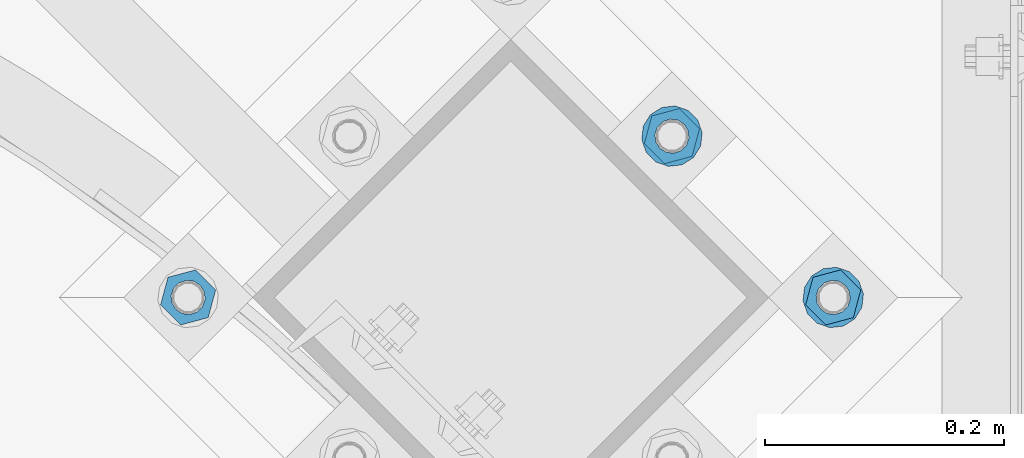
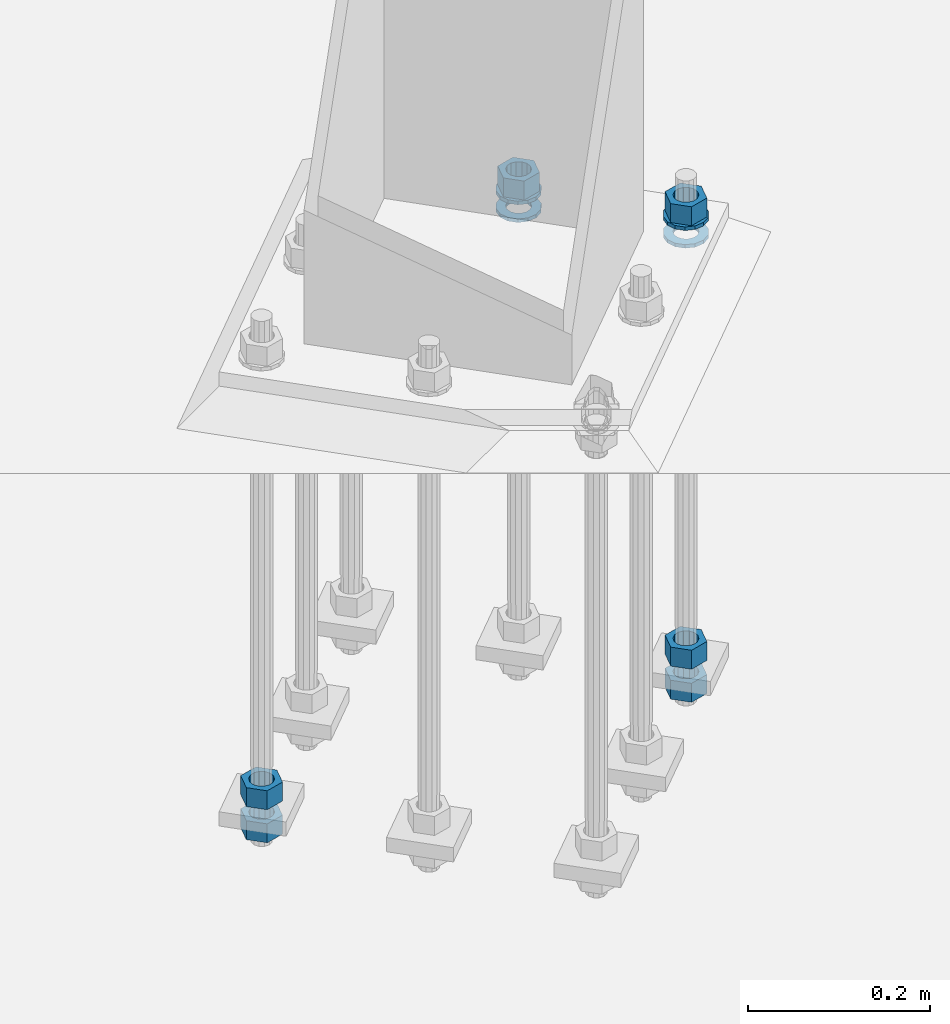
# One storey, part 875 of 1876: 10 columns, 1 element without a shape of its own.
"""IFC2X3 building model written with IfcOpenShell, lengths in millimetres."""

from ifc_helpers import new_model, si_unit, frame, origin_with_axes, place, context, subcontext, project, spatial, faceted_brep, material, type_object, element, aggregate, save


model = new_model("IFC2X3")

# Units and contexts
model_context = context("Model", 3, precision=1e-05, world=origin_with_axes())
body_context = subcontext(model_context, "Body", "Model", "MODEL_VIEW")
ifc_project = project(units=[si_unit("LENGTHUNIT", "METRE", prefix="MILLI"), si_unit("AREAUNIT", "SQUARE_METRE"), si_unit("VOLUMEUNIT", "CUBIC_METRE"), si_unit("MASSUNIT", "GRAM", prefix="KILO"), si_unit("TIMEUNIT", "SECOND"), si_unit("PLANEANGLEUNIT", "RADIAN"), si_unit("SOLIDANGLEUNIT", "STERADIAN"), si_unit("THERMODYNAMICTEMPERATUREUNIT", "DEGREE_CELSIUS"), si_unit("LUMINOUSINTENSITYUNIT", "LUMEN")], contexts=[model_context])

# Site, building, storey
site_placement = place(None, origin_with_axes())
site = spatial("IfcSite", under=ifc_project, at=site_placement, CompositionType="ELEMENT")
building_placement = place(site_placement, origin_with_axes())
building = spatial("IfcBuilding", under=site, at=building_placement, Name="Undefined", CompositionType="ELEMENT")
storey_placement = place(building_placement, origin_with_axes())
storey = spatial("IfcBuildingStorey", under=building, at=storey_placement, Name="Undefined", CompositionType="ELEMENT", Elevation=0.0)

# Assembly, columns
assembly_placement = place(storey_placement, origin_with_axes())
assembly = element("IfcElementAssembly", 1, at=assembly_placement, inside=storey, Name="TEMPLATE", AssemblyPlace="NOTDEFINED", PredefinedType="RIGID_FRAME")
ifc_material_1 = material(Name="STEEL/A563")
column_type_1 = type_object("IfcColumnType", Name="1_HEAVY_HEX_NUT", PredefinedType="NOTDEFINED")
column_1_placement = place(assembly_placement, frame((6849.68257448893, -12190.3251091436, 87.3125), z_axis=(0.707106781186548, 0.707106781186547, 0.0), x_axis=(0.0, 0.0, -1.0)))
column_1 = element("IfcColumn", 2, at=column_1_placement, type_object=column_type_1, material=ifc_material_1, Name="NUT", ObjectType="1_HEAVY_HEX_NUT", context=body_context, shape_type="Brep", body=[
    faceted_brep([(0.0, -23.8099994659442, 9.09494701772928e-13), (0.0, -11.9099998474121, -20.6200008392352), (25.4, -11.9099998474157, -20.6200008392361), (25.4, -23.8099994659478, 0.0), (0.0, 11.9099998474157, -20.620000839237), (25.4, 11.9099998474121, -20.620000839237), (0.0, 23.8099994659478, 9.09494701772928e-13), (25.4, 23.8099994659442, 0.0), (0.0, 11.9099998474157, 20.620000839237), (25.4, 11.9099998474121, 20.620000839237), (0.0, -11.9099998474121, 20.6200008392389), (25.4, -11.9099998474157, 20.6200008392379), (0.0, 1.81898940354586e-12, 14.2899999618567), (0.0, 6.20019861543915, 12.8748450879584), (25.4, 6.20019861543733, 12.8748450879593), (25.4, 0.0, 14.2899999618558), (0.0, 11.1723718546473, 8.90966924477925), (25.4, 11.1723718546436, 8.90966924477925), (0.0, 13.9317198278914, 3.17982413774916), (25.4, 13.9317198278877, 3.17982413775007), (0.0, 13.9317198278914, -3.17982413774644), (25.4, 13.9317198278895, -3.17982413774735), (0.0, 11.1723718546473, -8.90966924477834), (25.4, 11.1723718546455, -8.90966924477925), (0.0, 6.20019861544279, -12.8748450879575), (25.4, 6.20019861543915, -12.8748450879584), (0.0, 3.63797880709171e-12, -14.2899999618548), (25.4, -3.63797880709171e-12, -14.2899999618548), (0.0, -6.20019861543733, -12.8748450879566), (25.4, -6.20019861544097, -12.8748450879584), (0.0, -11.1723718546455, -8.90966924477743), (25.4, -11.1723718546473, -8.90966924477834), (0.0, -13.9317198278877, -3.17982413774735), (25.4, -13.9317198278914, -3.17982413774826), (0.0, -13.9317198278895, 3.17982413774735), (25.4, -13.9317198278914, 3.17982413774826), (0.0, -11.1723718546455, 8.90966924477925), (25.4, -11.1723718546473, 8.90966924478016), (0.0, -6.20019861543915, 12.8748450879593), (25.4, -6.20019861544279, 12.8748450879593)], [[[0, 1, 2, 3]], [[1, 4, 5, 2]], [[4, 6, 7, 5]], [[6, 8, 9, 7]], [[8, 10, 11, 9]], [[10, 0, 3, 11]], [[12, 13, 14, 15]], [[13, 16, 17, 14]], [[16, 18, 19, 17]], [[18, 20, 21, 19]], [[20, 22, 23, 21]], [[22, 24, 25, 23]], [[24, 26, 27, 25]], [[26, 28, 29, 27]], [[28, 30, 31, 29]], [[30, 32, 33, 31]], [[32, 34, 35, 33]], [[34, 36, 37, 35]], [[36, 38, 39, 37]], [[38, 12, 15, 39]], [[5, 7, 9, 11, 3, 2], [17, 19, 21, 23, 25, 27, 29, 31, 33, 35, 37, 39, 15, 14]], [[10, 8, 6, 4, 1, 0], [38, 36, 34, 32, 30, 28, 26, 24, 22, 20, 18, 16, 13, 12]]]),
])
column_2_placement = place(assembly_placement, frame((6849.68257448893, -12190.3251091436, -508.0), z_axis=(0.707106781186548, 0.707106781186547, 0.0), x_axis=(0.0, 0.0, -1.0)))
column_2 = element("IfcColumn", 3, at=column_2_placement, type_object=column_type_1, material=ifc_material_1, Name="NUT", ObjectType="1_HEAVY_HEX_NUT", context=body_context, shape_type="Brep", body=[
    faceted_brep([(0.0, -23.8099994659442, 9.09494701772928e-13), (0.0, -11.9099998474121, -20.6200008392352), (25.4, -11.9099998474157, -20.6200008392361), (25.4, -23.8099994659478, 0.0), (0.0, 11.9099998474157, -20.620000839237), (25.4, 11.9099998474121, -20.620000839237), (0.0, 23.8099994659478, 9.09494701772928e-13), (25.4, 23.8099994659442, 0.0), (0.0, 11.9099998474157, 20.620000839237), (25.4, 11.9099998474121, 20.620000839237), (0.0, -11.9099998474121, 20.6200008392389), (25.4, -11.9099998474157, 20.6200008392379), (0.0, 1.81898940354586e-12, 14.2899999618567), (0.0, 6.20019861543915, 12.8748450879584), (25.4, 6.20019861543733, 12.8748450879593), (25.4, 0.0, 14.2899999618558), (0.0, 11.1723718546473, 8.90966924477925), (25.4, 11.1723718546436, 8.90966924477925), (0.0, 13.9317198278914, 3.17982413774916), (25.4, 13.9317198278877, 3.17982413775007), (0.0, 13.9317198278914, -3.17982413774644), (25.4, 13.9317198278895, -3.17982413774735), (0.0, 11.1723718546473, -8.90966924477834), (25.4, 11.1723718546455, -8.90966924477925), (0.0, 6.20019861544279, -12.8748450879575), (25.4, 6.20019861543915, -12.8748450879584), (0.0, 3.63797880709171e-12, -14.2899999618548), (25.4, -3.63797880709171e-12, -14.2899999618548), (0.0, -6.20019861543733, -12.8748450879566), (25.4, -6.20019861544097, -12.8748450879584), (0.0, -11.1723718546455, -8.90966924477743), (25.4, -11.1723718546473, -8.90966924477834), (0.0, -13.9317198278877, -3.17982413774735), (25.4, -13.9317198278914, -3.17982413774826), (0.0, -13.9317198278895, 3.17982413774735), (25.4, -13.9317198278914, 3.17982413774826), (0.0, -11.1723718546455, 8.90966924477925), (25.4, -11.1723718546473, 8.90966924478016), (0.0, -6.20019861543915, 12.8748450879593), (25.4, -6.20019861544279, 12.8748450879593)], [[[0, 1, 2, 3]], [[1, 4, 5, 2]], [[4, 6, 7, 5]], [[6, 8, 9, 7]], [[8, 10, 11, 9]], [[10, 0, 3, 11]], [[12, 13, 14, 15]], [[13, 16, 17, 14]], [[16, 18, 19, 17]], [[18, 20, 21, 19]], [[20, 22, 23, 21]], [[22, 24, 25, 23]], [[24, 26, 27, 25]], [[26, 28, 29, 27]], [[28, 30, 31, 29]], [[30, 32, 33, 31]], [[32, 34, 35, 33]], [[34, 36, 37, 35]], [[36, 38, 39, 37]], [[38, 12, 15, 39]], [[5, 7, 9, 11, 3, 2], [17, 19, 21, 23, 25, 27, 29, 31, 33, 35, 37, 39, 15, 14]], [[10, 8, 6, 4, 1, 0], [38, 36, 34, 32, 30, 28, 26, 24, 22, 20, 18, 16, 13, 12]]]),
])
column_3_placement = place(assembly_placement, frame((6849.68257448893, -12190.3251091436, -552.45), z_axis=(0.707106781186548, 0.707106781186547, 0.0), x_axis=(0.0, 0.0, -1.0)))
column_3 = element("IfcColumn", 4, at=column_3_placement, type_object=column_type_1, material=ifc_material_1, Name="NUT", ObjectType="1_HEAVY_HEX_NUT", context=body_context, shape_type="Brep", body=[
    faceted_brep([(0.0, -23.8099994659442, 9.09494701772928e-13), (0.0, -11.9099998474121, -20.6200008392352), (25.4, -11.9099998474157, -20.6200008392361), (25.4, -23.8099994659478, 0.0), (0.0, 11.9099998474157, -20.620000839237), (25.4, 11.9099998474121, -20.620000839237), (0.0, 23.8099994659478, 9.09494701772928e-13), (25.4, 23.8099994659442, 0.0), (0.0, 11.9099998474157, 20.620000839237), (25.4, 11.9099998474121, 20.620000839237), (0.0, -11.9099998474121, 20.6200008392389), (25.4, -11.9099998474157, 20.6200008392379), (0.0, 1.81898940354586e-12, 14.2899999618567), (0.0, 6.20019861543915, 12.8748450879584), (25.4, 6.20019861543733, 12.8748450879593), (25.4, 0.0, 14.2899999618558), (0.0, 11.1723718546473, 8.90966924477925), (25.4, 11.1723718546436, 8.90966924477925), (0.0, 13.9317198278914, 3.17982413774916), (25.4, 13.9317198278877, 3.17982413775007), (0.0, 13.9317198278914, -3.17982413774644), (25.4, 13.9317198278895, -3.17982413774735), (0.0, 11.1723718546473, -8.90966924477834), (25.4, 11.1723718546455, -8.90966924477925), (0.0, 6.20019861544279, -12.8748450879575), (25.4, 6.20019861543915, -12.8748450879584), (0.0, 3.63797880709171e-12, -14.2899999618548), (25.4, -3.63797880709171e-12, -14.2899999618548), (0.0, -6.20019861543733, -12.8748450879566), (25.4, -6.20019861544097, -12.8748450879584), (0.0, -11.1723718546455, -8.90966924477743), (25.4, -11.1723718546473, -8.90966924477834), (0.0, -13.9317198278877, -3.17982413774735), (25.4, -13.9317198278914, -3.17982413774826), (0.0, -13.9317198278895, 3.17982413774735), (25.4, -13.9317198278914, 3.17982413774826), (0.0, -11.1723718546455, 8.90966924477925), (25.4, -11.1723718546473, 8.90966924478016), (0.0, -6.20019861543915, 12.8748450879593), (25.4, -6.20019861544279, 12.8748450879593)], [[[0, 1, 2, 3]], [[1, 4, 5, 2]], [[4, 6, 7, 5]], [[6, 8, 9, 7]], [[8, 10, 11, 9]], [[10, 0, 3, 11]], [[12, 13, 14, 15]], [[13, 16, 17, 14]], [[16, 18, 19, 17]], [[18, 20, 21, 19]], [[20, 22, 23, 21]], [[22, 24, 25, 23]], [[24, 26, 27, 25]], [[26, 28, 29, 27]], [[28, 30, 31, 29]], [[30, 32, 33, 31]], [[32, 34, 35, 33]], [[34, 36, 37, 35]], [[36, 38, 39, 37]], [[38, 12, 15, 39]], [[5, 7, 9, 11, 3, 2], [17, 19, 21, 23, 25, 27, 29, 31, 33, 35, 37, 39, 15, 14]], [[10, 8, 6, 4, 1, 0], [38, 36, 34, 32, 30, 28, 26, 24, 22, 20, 18, 16, 13, 12]]]),
])
column_4_placement = place(assembly_placement, frame((6714.97873267278, -12055.6212673274, 87.3125), z_axis=(0.707106781186548, 0.707106781186547, 0.0), x_axis=(0.0, 0.0, -1.0)))
column_4 = element("IfcColumn", 5, at=column_4_placement, type_object=column_type_1, material=ifc_material_1, Name="NUT", ObjectType="1_HEAVY_HEX_NUT", context=body_context, shape_type="Brep", body=[
    faceted_brep([(0.0, -23.8099994659442, 9.09494701772928e-13), (0.0, -11.9099998474121, -20.6200008392352), (25.4, -11.9099998474157, -20.6200008392361), (25.4, -23.8099994659478, 0.0), (0.0, 11.9099998474157, -20.620000839237), (25.4, 11.9099998474121, -20.620000839237), (0.0, 23.8099994659478, 9.09494701772928e-13), (25.4, 23.8099994659442, 0.0), (0.0, 11.9099998474157, 20.620000839237), (25.4, 11.9099998474121, 20.620000839237), (0.0, -11.9099998474121, 20.6200008392389), (25.4, -11.9099998474157, 20.6200008392379), (0.0, 1.81898940354586e-12, 14.2899999618567), (0.0, 6.20019861543915, 12.8748450879584), (25.4, 6.20019861543733, 12.8748450879593), (25.4, 0.0, 14.2899999618558), (0.0, 11.1723718546473, 8.90966924477925), (25.4, 11.1723718546436, 8.90966924477925), (0.0, 13.9317198278914, 3.17982413774916), (25.4, 13.9317198278877, 3.17982413775007), (0.0, 13.9317198278914, -3.17982413774644), (25.4, 13.9317198278895, -3.17982413774735), (0.0, 11.1723718546473, -8.90966924477834), (25.4, 11.1723718546455, -8.90966924477925), (0.0, 6.20019861544279, -12.8748450879575), (25.4, 6.20019861543915, -12.8748450879584), (0.0, 3.63797880709171e-12, -14.2899999618548), (25.4, -3.63797880709171e-12, -14.2899999618548), (0.0, -6.20019861543733, -12.8748450879566), (25.4, -6.20019861544097, -12.8748450879584), (0.0, -11.1723718546455, -8.90966924477743), (25.4, -11.1723718546473, -8.90966924477834), (0.0, -13.9317198278877, -3.17982413774735), (25.4, -13.9317198278914, -3.17982413774826), (0.0, -13.9317198278895, 3.17982413774735), (25.4, -13.9317198278914, 3.17982413774826), (0.0, -11.1723718546455, 8.90966924477925), (25.4, -11.1723718546473, 8.90966924478016), (0.0, -6.20019861543915, 12.8748450879593), (25.4, -6.20019861544279, 12.8748450879593)], [[[0, 1, 2, 3]], [[1, 4, 5, 2]], [[4, 6, 7, 5]], [[6, 8, 9, 7]], [[8, 10, 11, 9]], [[10, 0, 3, 11]], [[12, 13, 14, 15]], [[13, 16, 17, 14]], [[16, 18, 19, 17]], [[18, 20, 21, 19]], [[20, 22, 23, 21]], [[22, 24, 25, 23]], [[24, 26, 27, 25]], [[26, 28, 29, 27]], [[28, 30, 31, 29]], [[30, 32, 33, 31]], [[32, 34, 35, 33]], [[34, 36, 37, 35]], [[36, 38, 39, 37]], [[38, 12, 15, 39]], [[5, 7, 9, 11, 3, 2], [17, 19, 21, 23, 25, 27, 29, 31, 33, 35, 37, 39, 15, 14]], [[10, 8, 6, 4, 1, 0], [38, 36, 34, 32, 30, 28, 26, 24, 22, 20, 18, 16, 13, 12]]]),
])
column_5_placement = place(assembly_placement, frame((6310.86720722432, -12190.3251091436, -508.0), z_axis=(-0.707106781186547, -0.707106781186548, 0.0), x_axis=(0.0, 0.0, -1.0)))
column_5 = element("IfcColumn", 6, at=column_5_placement, type_object=column_type_1, material=ifc_material_1, Name="NUT", ObjectType="1_HEAVY_HEX_NUT", context=body_context, shape_type="Brep", body=[
    faceted_brep([(0.0, -23.8099994659442, 9.09494701772928e-13), (0.0, -11.9099998474121, -20.6200008392352), (25.4, -11.9099998474157, -20.6200008392361), (25.4, -23.8099994659478, 0.0), (0.0, 11.9099998474157, -20.620000839237), (25.4, 11.9099998474121, -20.620000839237), (0.0, 23.8099994659478, 9.09494701772928e-13), (25.4, 23.8099994659442, 0.0), (0.0, 11.9099998474157, 20.620000839237), (25.4, 11.9099998474121, 20.620000839237), (0.0, -11.9099998474121, 20.6200008392389), (25.4, -11.9099998474157, 20.6200008392379), (0.0, 1.81898940354586e-12, 14.2899999618567), (0.0, 6.20019861543915, 12.8748450879584), (25.4, 6.20019861543733, 12.8748450879593), (25.4, 0.0, 14.2899999618558), (0.0, 11.1723718546473, 8.90966924477925), (25.4, 11.1723718546436, 8.90966924477925), (0.0, 13.9317198278914, 3.17982413774916), (25.4, 13.9317198278877, 3.17982413775007), (0.0, 13.9317198278914, -3.17982413774644), (25.4, 13.9317198278895, -3.17982413774735), (0.0, 11.1723718546473, -8.90966924477834), (25.4, 11.1723718546455, -8.90966924477925), (0.0, 6.20019861544279, -12.8748450879575), (25.4, 6.20019861543915, -12.8748450879584), (0.0, 3.63797880709171e-12, -14.2899999618548), (25.4, -3.63797880709171e-12, -14.2899999618548), (0.0, -6.20019861543733, -12.8748450879566), (25.4, -6.20019861544097, -12.8748450879584), (0.0, -11.1723718546455, -8.90966924477743), (25.4, -11.1723718546473, -8.90966924477834), (0.0, -13.9317198278877, -3.17982413774735), (25.4, -13.9317198278914, -3.17982413774826), (0.0, -13.9317198278895, 3.17982413774735), (25.4, -13.9317198278914, 3.17982413774826), (0.0, -11.1723718546455, 8.90966924477925), (25.4, -11.1723718546473, 8.90966924478016), (0.0, -6.20019861543915, 12.8748450879593), (25.4, -6.20019861544279, 12.8748450879593)], [[[0, 1, 2, 3]], [[1, 4, 5, 2]], [[4, 6, 7, 5]], [[6, 8, 9, 7]], [[8, 10, 11, 9]], [[10, 0, 3, 11]], [[12, 13, 14, 15]], [[13, 16, 17, 14]], [[16, 18, 19, 17]], [[18, 20, 21, 19]], [[20, 22, 23, 21]], [[22, 24, 25, 23]], [[24, 26, 27, 25]], [[26, 28, 29, 27]], [[28, 30, 31, 29]], [[30, 32, 33, 31]], [[32, 34, 35, 33]], [[34, 36, 37, 35]], [[36, 38, 39, 37]], [[38, 12, 15, 39]], [[5, 7, 9, 11, 3, 2], [17, 19, 21, 23, 25, 27, 29, 31, 33, 35, 37, 39, 15, 14]], [[10, 8, 6, 4, 1, 0], [38, 36, 34, 32, 30, 28, 26, 24, 22, 20, 18, 16, 13, 12]]]),
])
column_6_placement = place(assembly_placement, frame((6310.86720722432, -12190.3251091436, -552.45), z_axis=(-0.707106781186547, -0.707106781186548, 0.0), x_axis=(0.0, 0.0, -1.0)))
column_6 = element("IfcColumn", 7, at=column_6_placement, type_object=column_type_1, material=ifc_material_1, Name="NUT", ObjectType="1_HEAVY_HEX_NUT", context=body_context, shape_type="Brep", body=[
    faceted_brep([(0.0, -23.8099994659442, 9.09494701772928e-13), (0.0, -11.9099998474121, -20.6200008392352), (25.4, -11.9099998474157, -20.6200008392361), (25.4, -23.8099994659478, 0.0), (0.0, 11.9099998474157, -20.620000839237), (25.4, 11.9099998474121, -20.620000839237), (0.0, 23.8099994659478, 9.09494701772928e-13), (25.4, 23.8099994659442, 0.0), (0.0, 11.9099998474157, 20.620000839237), (25.4, 11.9099998474121, 20.620000839237), (0.0, -11.9099998474121, 20.6200008392389), (25.4, -11.9099998474157, 20.6200008392379), (0.0, 1.81898940354586e-12, 14.2899999618567), (0.0, 6.20019861543915, 12.8748450879584), (25.4, 6.20019861543733, 12.8748450879593), (25.4, 0.0, 14.2899999618558), (0.0, 11.1723718546473, 8.90966924477925), (25.4, 11.1723718546436, 8.90966924477925), (0.0, 13.9317198278914, 3.17982413774916), (25.4, 13.9317198278877, 3.17982413775007), (0.0, 13.9317198278914, -3.17982413774644), (25.4, 13.9317198278895, -3.17982413774735), (0.0, 11.1723718546473, -8.90966924477834), (25.4, 11.1723718546455, -8.90966924477925), (0.0, 6.20019861544279, -12.8748450879575), (25.4, 6.20019861543915, -12.8748450879584), (0.0, 3.63797880709171e-12, -14.2899999618548), (25.4, -3.63797880709171e-12, -14.2899999618548), (0.0, -6.20019861543733, -12.8748450879566), (25.4, -6.20019861544097, -12.8748450879584), (0.0, -11.1723718546455, -8.90966924477743), (25.4, -11.1723718546473, -8.90966924477834), (0.0, -13.9317198278877, -3.17982413774735), (25.4, -13.9317198278914, -3.17982413774826), (0.0, -13.9317198278895, 3.17982413774735), (25.4, -13.9317198278914, 3.17982413774826), (0.0, -11.1723718546455, 8.90966924477925), (25.4, -11.1723718546473, 8.90966924478016), (0.0, -6.20019861543915, 12.8748450879593), (25.4, -6.20019861544279, 12.8748450879593)], [[[0, 1, 2, 3]], [[1, 4, 5, 2]], [[4, 6, 7, 5]], [[6, 8, 9, 7]], [[8, 10, 11, 9]], [[10, 0, 3, 11]], [[12, 13, 14, 15]], [[13, 16, 17, 14]], [[16, 18, 19, 17]], [[18, 20, 21, 19]], [[20, 22, 23, 21]], [[22, 24, 25, 23]], [[24, 26, 27, 25]], [[26, 28, 29, 27]], [[28, 30, 31, 29]], [[30, 32, 33, 31]], [[32, 34, 35, 33]], [[34, 36, 37, 35]], [[36, 38, 39, 37]], [[38, 12, 15, 39]], [[5, 7, 9, 11, 3, 2], [17, 19, 21, 23, 25, 27, 29, 31, 33, 35, 37, 39, 15, 14]], [[10, 8, 6, 4, 1, 0], [38, 36, 34, 32, 30, 28, 26, 24, 22, 20, 18, 16, 13, 12]]]),
])
ifc_material_2 = material(Name="STEEL/F436")
column_type_2 = type_object("IfcColumnType", Name="1_WASHER", PredefinedType="NOTDEFINED")
column_7_placement = place(assembly_placement, frame((6849.68257448893, -12190.3251091436, 38.1), z_axis=(0.707106781186548, 0.707106781186547, 0.0), x_axis=(0.0, 0.0, -1.0)))
column_7 = element("IfcColumn", 8, at=column_7_placement, type_object=column_type_2, material=ifc_material_2, Name="WASHER", ObjectType="1_WASHER", context=body_context, shape_type="Brep", body=[
    faceted_brep([(0.0, -25.3999996185375, 0.0), (0.0, -22.8846089010331, -11.0206468080742), (4.7625, -22.8846089010331, -11.0206468080742), (4.7625, -25.3999996185375, 0.0), (0.0, -15.8366407293743, -19.8585193564477), (4.7625, -15.8366407293743, -19.8585193564477), (0.0, -5.65203163760816, -24.7631685975166), (4.7625, -5.65203163760816, -24.7631685975166), (0.0, 5.65203163760452, -24.7631685975166), (4.7625, 5.65203163760452, -24.7631685975166), (0.0, 15.8366407293706, -19.858519356445), (4.7625, 15.8366407293706, -19.858519356445), (0.0, 22.8846089010331, -11.0206468080733), (4.7625, 22.8846089010331, -11.0206468080733), (0.0, 25.3999996185339, 9.09494701772928e-13), (4.7625, 25.3999996185339, 9.09494701772928e-13), (0.0, 22.8846089010331, 11.0206468080751), (4.7625, 22.8846089010331, 11.0206468080751), (0.0, 15.8366407293706, 19.8585193564486), (4.7625, 15.8366407293706, 19.8585193564486), (0.0, 5.65203163760452, 24.7631685975175), (4.7625, 5.65203163760452, 24.7631685975175), (0.0, -5.65203163760816, 24.7631685975175), (4.7625, -5.65203163760816, 24.7631685975175), (0.0, -15.8366407293724, 19.8585193564459), (4.7625, -15.8366407293724, 19.8585193564459), (0.0, -22.8846089010367, 11.0206468080751), (4.7625, -22.8846089010367, 11.0206468080751), (0.0, 1.81898940354586e-12, 14.2899999618567), (0.0, 6.20019861543915, 12.8748450879584), (4.7625, 6.20019861543733, 12.8748450879593), (4.7625, 0.0, 14.2899999618558), (0.0, 11.1723718546473, 8.90966924477925), (4.7625, 11.1723718546436, 8.90966924477925), (0.0, 13.9317198278914, 3.17982413774916), (4.7625, 13.9317198278877, 3.17982413775007), (0.0, 13.9317198278914, -3.17982413774644), (4.7625, 13.9317198278895, -3.17982413774735), (0.0, 11.1723718546473, -8.90966924477834), (4.7625, 11.1723718546455, -8.90966924477925), (0.0, 6.20019861544279, -12.8748450879575), (4.7625, 6.20019861543915, -12.8748450879584), (0.0, 3.63797880709171e-12, -14.2899999618548), (4.7625, -3.63797880709171e-12, -14.2899999618548), (0.0, -6.20019861543733, -12.8748450879566), (4.7625, -6.20019861544097, -12.8748450879584), (0.0, -11.1723718546455, -8.90966924477743), (4.7625, -11.1723718546473, -8.90966924477834), (0.0, -13.9317198278877, -3.17982413774735), (4.7625, -13.9317198278914, -3.17982413774826), (0.0, -13.9317198278895, 3.17982413774735), (4.7625, -13.9317198278914, 3.17982413774826), (0.0, -11.1723718546455, 8.90966924477925), (4.7625, -11.1723718546473, 8.90966924478016), (0.0, -6.20019861543915, 12.8748450879593), (4.7625, -6.20019861544279, 12.8748450879593)], [[[0, 1, 2, 3]], [[1, 4, 5, 2]], [[4, 6, 7, 5]], [[6, 8, 9, 7]], [[8, 10, 11, 9]], [[10, 12, 13, 11]], [[12, 14, 15, 13]], [[14, 16, 17, 15]], [[16, 18, 19, 17]], [[18, 20, 21, 19]], [[20, 22, 23, 21]], [[22, 24, 25, 23]], [[24, 26, 27, 25]], [[26, 0, 3, 27]], [[28, 29, 30, 31]], [[29, 32, 33, 30]], [[32, 34, 35, 33]], [[34, 36, 37, 35]], [[36, 38, 39, 37]], [[38, 40, 41, 39]], [[40, 42, 43, 41]], [[42, 44, 45, 43]], [[44, 46, 47, 45]], [[46, 48, 49, 47]], [[48, 50, 51, 49]], [[50, 52, 53, 51]], [[52, 54, 55, 53]], [[54, 28, 31, 55]], [[5, 7, 9, 11, 13, 15, 17, 19, 21, 23, 25, 27, 3, 2], [33, 35, 37, 39, 41, 43, 45, 47, 49, 51, 53, 55, 31, 30]], [[26, 24, 22, 20, 18, 16, 14, 12, 10, 8, 6, 4, 1, 0], [54, 52, 50, 48, 46, 44, 42, 40, 38, 36, 34, 32, 29, 28]]]),
])
column_8_placement = place(assembly_placement, frame((6849.68257448893, -12190.3251091436, 61.9125), z_axis=(0.707106781186548, 0.707106781186547, 0.0), x_axis=(0.0, 0.0, -1.0)))
column_8 = element("IfcColumn", 9, at=column_8_placement, type_object=column_type_2, material=ifc_material_2, Name="WASHER", ObjectType="1_WASHER", context=body_context, shape_type="Brep", body=[
    faceted_brep([(0.0, -25.3999996185375, 0.0), (0.0, -22.8846089010331, -11.0206468080742), (4.7625, -22.8846089010331, -11.0206468080742), (4.7625, -25.3999996185375, 0.0), (0.0, -15.8366407293743, -19.8585193564477), (4.7625, -15.8366407293743, -19.8585193564477), (0.0, -5.65203163760816, -24.7631685975166), (4.7625, -5.65203163760816, -24.7631685975166), (0.0, 5.65203163760452, -24.7631685975166), (4.7625, 5.65203163760452, -24.7631685975166), (0.0, 15.8366407293706, -19.858519356445), (4.7625, 15.8366407293706, -19.858519356445), (0.0, 22.8846089010331, -11.0206468080733), (4.7625, 22.8846089010331, -11.0206468080733), (0.0, 25.3999996185339, 9.09494701772928e-13), (4.7625, 25.3999996185339, 9.09494701772928e-13), (0.0, 22.8846089010331, 11.0206468080751), (4.7625, 22.8846089010331, 11.0206468080751), (0.0, 15.8366407293706, 19.8585193564486), (4.7625, 15.8366407293706, 19.8585193564486), (0.0, 5.65203163760452, 24.7631685975175), (4.7625, 5.65203163760452, 24.7631685975175), (0.0, -5.65203163760816, 24.7631685975175), (4.7625, -5.65203163760816, 24.7631685975175), (0.0, -15.8366407293724, 19.8585193564459), (4.7625, -15.8366407293724, 19.8585193564459), (0.0, -22.8846089010367, 11.0206468080751), (4.7625, -22.8846089010367, 11.0206468080751), (0.0, 1.81898940354586e-12, 14.2899999618567), (0.0, 6.20019861543915, 12.8748450879584), (4.7625, 6.20019861543733, 12.8748450879593), (4.7625, 0.0, 14.2899999618558), (0.0, 11.1723718546473, 8.90966924477925), (4.7625, 11.1723718546436, 8.90966924477925), (0.0, 13.9317198278914, 3.17982413774916), (4.7625, 13.9317198278877, 3.17982413775007), (0.0, 13.9317198278914, -3.17982413774644), (4.7625, 13.9317198278895, -3.17982413774735), (0.0, 11.1723718546473, -8.90966924477834), (4.7625, 11.1723718546455, -8.90966924477925), (0.0, 6.20019861544279, -12.8748450879575), (4.7625, 6.20019861543915, -12.8748450879584), (0.0, 3.63797880709171e-12, -14.2899999618548), (4.7625, -3.63797880709171e-12, -14.2899999618548), (0.0, -6.20019861543733, -12.8748450879566), (4.7625, -6.20019861544097, -12.8748450879584), (0.0, -11.1723718546455, -8.90966924477743), (4.7625, -11.1723718546473, -8.90966924477834), (0.0, -13.9317198278877, -3.17982413774735), (4.7625, -13.9317198278914, -3.17982413774826), (0.0, -13.9317198278895, 3.17982413774735), (4.7625, -13.9317198278914, 3.17982413774826), (0.0, -11.1723718546455, 8.90966924477925), (4.7625, -11.1723718546473, 8.90966924478016), (0.0, -6.20019861543915, 12.8748450879593), (4.7625, -6.20019861544279, 12.8748450879593)], [[[0, 1, 2, 3]], [[1, 4, 5, 2]], [[4, 6, 7, 5]], [[6, 8, 9, 7]], [[8, 10, 11, 9]], [[10, 12, 13, 11]], [[12, 14, 15, 13]], [[14, 16, 17, 15]], [[16, 18, 19, 17]], [[18, 20, 21, 19]], [[20, 22, 23, 21]], [[22, 24, 25, 23]], [[24, 26, 27, 25]], [[26, 0, 3, 27]], [[28, 29, 30, 31]], [[29, 32, 33, 30]], [[32, 34, 35, 33]], [[34, 36, 37, 35]], [[36, 38, 39, 37]], [[38, 40, 41, 39]], [[40, 42, 43, 41]], [[42, 44, 45, 43]], [[44, 46, 47, 45]], [[46, 48, 49, 47]], [[48, 50, 51, 49]], [[50, 52, 53, 51]], [[52, 54, 55, 53]], [[54, 28, 31, 55]], [[5, 7, 9, 11, 13, 15, 17, 19, 21, 23, 25, 27, 3, 2], [33, 35, 37, 39, 41, 43, 45, 47, 49, 51, 53, 55, 31, 30]], [[26, 24, 22, 20, 18, 16, 14, 12, 10, 8, 6, 4, 1, 0], [54, 52, 50, 48, 46, 44, 42, 40, 38, 36, 34, 32, 29, 28]]]),
])
column_9_placement = place(assembly_placement, frame((6714.97873267278, -12055.6212673274, 38.1), z_axis=(0.707106781186548, 0.707106781186547, 0.0), x_axis=(0.0, 0.0, -1.0)))
column_9 = element("IfcColumn", 10, at=column_9_placement, type_object=column_type_2, material=ifc_material_2, Name="WASHER", ObjectType="1_WASHER", context=body_context, shape_type="Brep", body=[
    faceted_brep([(0.0, -25.3999996185375, 0.0), (0.0, -22.8846089010331, -11.0206468080742), (4.7625, -22.8846089010331, -11.0206468080742), (4.7625, -25.3999996185375, 0.0), (0.0, -15.8366407293743, -19.8585193564477), (4.7625, -15.8366407293743, -19.8585193564477), (0.0, -5.65203163760816, -24.7631685975166), (4.7625, -5.65203163760816, -24.7631685975166), (0.0, 5.65203163760452, -24.7631685975166), (4.7625, 5.65203163760452, -24.7631685975166), (0.0, 15.8366407293706, -19.858519356445), (4.7625, 15.8366407293706, -19.858519356445), (0.0, 22.8846089010331, -11.0206468080733), (4.7625, 22.8846089010331, -11.0206468080733), (0.0, 25.3999996185339, 9.09494701772928e-13), (4.7625, 25.3999996185339, 9.09494701772928e-13), (0.0, 22.8846089010331, 11.0206468080751), (4.7625, 22.8846089010331, 11.0206468080751), (0.0, 15.8366407293706, 19.8585193564486), (4.7625, 15.8366407293706, 19.8585193564486), (0.0, 5.65203163760452, 24.7631685975175), (4.7625, 5.65203163760452, 24.7631685975175), (0.0, -5.65203163760816, 24.7631685975175), (4.7625, -5.65203163760816, 24.7631685975175), (0.0, -15.8366407293724, 19.8585193564459), (4.7625, -15.8366407293724, 19.8585193564459), (0.0, -22.8846089010367, 11.0206468080751), (4.7625, -22.8846089010367, 11.0206468080751), (0.0, 1.81898940354586e-12, 14.2899999618567), (0.0, 6.20019861543915, 12.8748450879584), (4.7625, 6.20019861543733, 12.8748450879593), (4.7625, 0.0, 14.2899999618558), (0.0, 11.1723718546473, 8.90966924477925), (4.7625, 11.1723718546436, 8.90966924477925), (0.0, 13.9317198278914, 3.17982413774916), (4.7625, 13.9317198278877, 3.17982413775007), (0.0, 13.9317198278914, -3.17982413774644), (4.7625, 13.9317198278895, -3.17982413774735), (0.0, 11.1723718546473, -8.90966924477834), (4.7625, 11.1723718546455, -8.90966924477925), (0.0, 6.20019861544279, -12.8748450879575), (4.7625, 6.20019861543915, -12.8748450879584), (0.0, 3.63797880709171e-12, -14.2899999618548), (4.7625, -3.63797880709171e-12, -14.2899999618548), (0.0, -6.20019861543733, -12.8748450879566), (4.7625, -6.20019861544097, -12.8748450879584), (0.0, -11.1723718546455, -8.90966924477743), (4.7625, -11.1723718546473, -8.90966924477834), (0.0, -13.9317198278877, -3.17982413774735), (4.7625, -13.9317198278914, -3.17982413774826), (0.0, -13.9317198278895, 3.17982413774735), (4.7625, -13.9317198278914, 3.17982413774826), (0.0, -11.1723718546455, 8.90966924477925), (4.7625, -11.1723718546473, 8.90966924478016), (0.0, -6.20019861543915, 12.8748450879593), (4.7625, -6.20019861544279, 12.8748450879593)], [[[0, 1, 2, 3]], [[1, 4, 5, 2]], [[4, 6, 7, 5]], [[6, 8, 9, 7]], [[8, 10, 11, 9]], [[10, 12, 13, 11]], [[12, 14, 15, 13]], [[14, 16, 17, 15]], [[16, 18, 19, 17]], [[18, 20, 21, 19]], [[20, 22, 23, 21]], [[22, 24, 25, 23]], [[24, 26, 27, 25]], [[26, 0, 3, 27]], [[28, 29, 30, 31]], [[29, 32, 33, 30]], [[32, 34, 35, 33]], [[34, 36, 37, 35]], [[36, 38, 39, 37]], [[38, 40, 41, 39]], [[40, 42, 43, 41]], [[42, 44, 45, 43]], [[44, 46, 47, 45]], [[46, 48, 49, 47]], [[48, 50, 51, 49]], [[50, 52, 53, 51]], [[52, 54, 55, 53]], [[54, 28, 31, 55]], [[5, 7, 9, 11, 13, 15, 17, 19, 21, 23, 25, 27, 3, 2], [33, 35, 37, 39, 41, 43, 45, 47, 49, 51, 53, 55, 31, 30]], [[26, 24, 22, 20, 18, 16, 14, 12, 10, 8, 6, 4, 1, 0], [54, 52, 50, 48, 46, 44, 42, 40, 38, 36, 34, 32, 29, 28]]]),
])
column_10_placement = place(assembly_placement, frame((6714.97873267278, -12055.6212673274, 61.9125), z_axis=(0.707106781186548, 0.707106781186547, 0.0), x_axis=(0.0, 0.0, -1.0)))
column_10 = element("IfcColumn", 11, at=column_10_placement, type_object=column_type_2, material=ifc_material_2, Name="WASHER", ObjectType="1_WASHER", context=body_context, shape_type="Brep", body=[
    faceted_brep([(0.0, -25.3999996185375, 0.0), (0.0, -22.8846089010331, -11.0206468080742), (4.7625, -22.8846089010331, -11.0206468080742), (4.7625, -25.3999996185375, 0.0), (0.0, -15.8366407293743, -19.8585193564477), (4.7625, -15.8366407293743, -19.8585193564477), (0.0, -5.65203163760816, -24.7631685975166), (4.7625, -5.65203163760816, -24.7631685975166), (0.0, 5.65203163760452, -24.7631685975166), (4.7625, 5.65203163760452, -24.7631685975166), (0.0, 15.8366407293706, -19.858519356445), (4.7625, 15.8366407293706, -19.858519356445), (0.0, 22.8846089010331, -11.0206468080733), (4.7625, 22.8846089010331, -11.0206468080733), (0.0, 25.3999996185339, 9.09494701772928e-13), (4.7625, 25.3999996185339, 9.09494701772928e-13), (0.0, 22.8846089010331, 11.0206468080751), (4.7625, 22.8846089010331, 11.0206468080751), (0.0, 15.8366407293706, 19.8585193564486), (4.7625, 15.8366407293706, 19.8585193564486), (0.0, 5.65203163760452, 24.7631685975175), (4.7625, 5.65203163760452, 24.7631685975175), (0.0, -5.65203163760816, 24.7631685975175), (4.7625, -5.65203163760816, 24.7631685975175), (0.0, -15.8366407293724, 19.8585193564459), (4.7625, -15.8366407293724, 19.8585193564459), (0.0, -22.8846089010367, 11.0206468080751), (4.7625, -22.8846089010367, 11.0206468080751), (0.0, 1.81898940354586e-12, 14.2899999618567), (0.0, 6.20019861543915, 12.8748450879584), (4.7625, 6.20019861543733, 12.8748450879593), (4.7625, 0.0, 14.2899999618558), (0.0, 11.1723718546473, 8.90966924477925), (4.7625, 11.1723718546436, 8.90966924477925), (0.0, 13.9317198278914, 3.17982413774916), (4.7625, 13.9317198278877, 3.17982413775007), (0.0, 13.9317198278914, -3.17982413774644), (4.7625, 13.9317198278895, -3.17982413774735), (0.0, 11.1723718546473, -8.90966924477834), (4.7625, 11.1723718546455, -8.90966924477925), (0.0, 6.20019861544279, -12.8748450879575), (4.7625, 6.20019861543915, -12.8748450879584), (0.0, 3.63797880709171e-12, -14.2899999618548), (4.7625, -3.63797880709171e-12, -14.2899999618548), (0.0, -6.20019861543733, -12.8748450879566), (4.7625, -6.20019861544097, -12.8748450879584), (0.0, -11.1723718546455, -8.90966924477743), (4.7625, -11.1723718546473, -8.90966924477834), (0.0, -13.9317198278877, -3.17982413774735), (4.7625, -13.9317198278914, -3.17982413774826), (0.0, -13.9317198278895, 3.17982413774735), (4.7625, -13.9317198278914, 3.17982413774826), (0.0, -11.1723718546455, 8.90966924477925), (4.7625, -11.1723718546473, 8.90966924478016), (0.0, -6.20019861543915, 12.8748450879593), (4.7625, -6.20019861544279, 12.8748450879593)], [[[0, 1, 2, 3]], [[1, 4, 5, 2]], [[4, 6, 7, 5]], [[6, 8, 9, 7]], [[8, 10, 11, 9]], [[10, 12, 13, 11]], [[12, 14, 15, 13]], [[14, 16, 17, 15]], [[16, 18, 19, 17]], [[18, 20, 21, 19]], [[20, 22, 23, 21]], [[22, 24, 25, 23]], [[24, 26, 27, 25]], [[26, 0, 3, 27]], [[28, 29, 30, 31]], [[29, 32, 33, 30]], [[32, 34, 35, 33]], [[34, 36, 37, 35]], [[36, 38, 39, 37]], [[38, 40, 41, 39]], [[40, 42, 43, 41]], [[42, 44, 45, 43]], [[44, 46, 47, 45]], [[46, 48, 49, 47]], [[48, 50, 51, 49]], [[50, 52, 53, 51]], [[52, 54, 55, 53]], [[54, 28, 31, 55]], [[5, 7, 9, 11, 13, 15, 17, 19, 21, 23, 25, 27, 3, 2], [33, 35, 37, 39, 41, 43, 45, 47, 49, 51, 53, 55, 31, 30]], [[26, 24, 22, 20, 18, 16, 14, 12, 10, 8, 6, 4, 1, 0], [54, 52, 50, 48, 46, 44, 42, 40, 38, 36, 34, 32, 29, 28]]]),
])
aggregate(assembly, [column_1, column_7, column_8, column_2, column_3, column_4, column_9, column_10, column_5, column_6])

save(model, "model.ifc")
